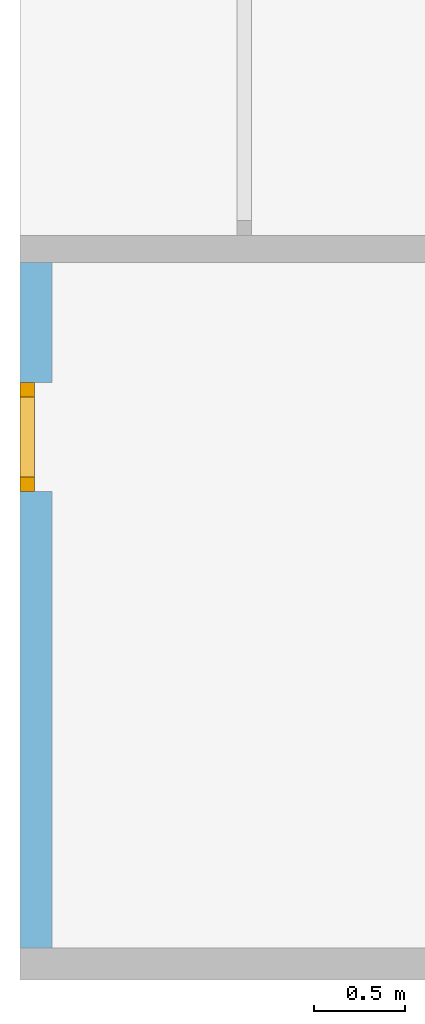
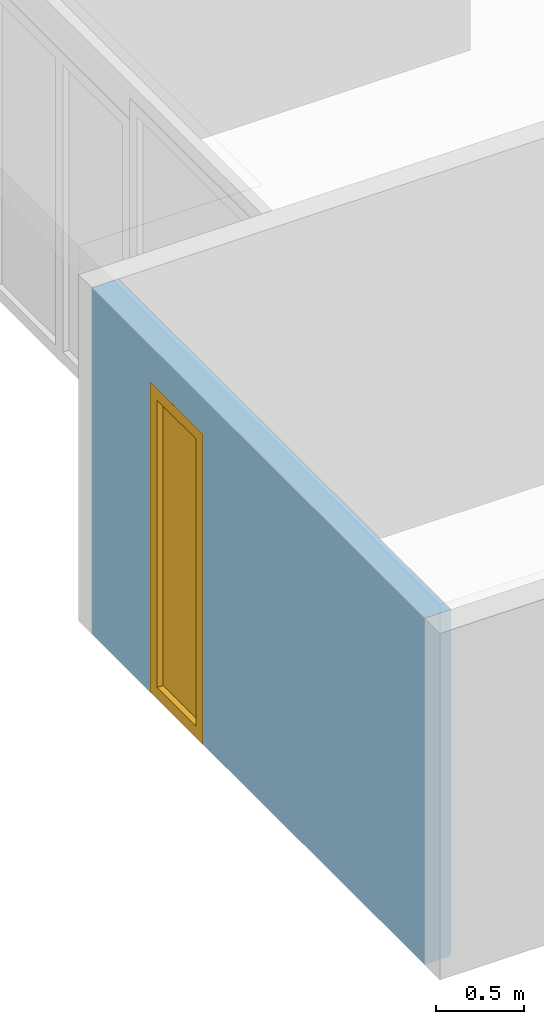
# One storey, part 2 of 8: 1 window, 1 opening, plus 1 element that does not belong to this part.
"""IFC2X3 building model written with IfcOpenShell, lengths in millimetres."""

from ifc_helpers import new_model, entity, si_unit, converted_unit, frame, frame_2d, origin, origin_with_axes, place, context, project, spatial, rectangle, extrude, faceted_brep, material, layer, layer_set, layer_usage, element, fill, save


model = new_model("IFC2X3")

# Units and contexts
model_context = context("Model", 3, precision=1e-05, world=origin())
plan_context = context("Plan", 3, precision=1e-05, world=origin())
ifc_project = project(units=[si_unit("LENGTHUNIT", "METRE", prefix="MILLI"), converted_unit("PLANEANGLEUNIT", "DEGREE", entity("IfcPlaneAngleMeasure", 0.0174532925199433), si_unit("PLANEANGLEUNIT", "RADIAN"), dimensions=[0, 0, 0, 0, 0, 0, 0]), si_unit("AREAUNIT", "SQUARE_METRE"), si_unit("VOLUMEUNIT", "CUBIC_METRE")], contexts=[model_context, plan_context])

# Building, storey
building_placement = place(None, origin())
building = spatial("IfcBuilding", under=ifc_project, at=building_placement, CompositionType="ELEMENT")
storey_placement = place(building_placement, frame((0.0, 0.0, 2900.0), z_axis=(0.0, 0.0, 1.0), x_axis=(1.0, 0.0, 0.0)))
storey = spatial("IfcBuildingStorey", under=building, at=storey_placement, Name="OG", CompositionType="ELEMENT", Elevation=2900.0)

# Wall, opening, window
ifc_material_1 = material(Name="B25")
ifc_layer = layer(ifc_material_1, 175.0)
ifc_layer_set = layer_set([ifc_layer])
ifc_layer_usage = layer_usage(ifc_layer_set, "AXIS2", "POSITIVE", 0.0)
wall_placement = place(storey_placement, frame((21188.3517822139, -4741.5625, 0.0), z_axis=(0.0, 0.0, 1.0), x_axis=(0.0, -1.0, 0.0)))
wall = element("IfcWallStandardCase", 1, at=wall_placement, inside=storey, material=ifc_layer_usage, context=model_context, shape_type="SweptSolid", body=[
    extrude(rectangle(XDim=3775.0, YDim=175.0, at=frame_2d((1887.5, 87.5), x_axis=(1.0, 0.0))), origin_with_axes(), (0.0, 0.0, 1.0), 2400.0),
])
opening_placement = place(wall_placement, frame((660.000000000001, 0.0, 0.0), z_axis=(0.0, 1.0, 0.0), x_axis=(0.0, 0.0, 1.0)))
opening = element("IfcOpeningElement", 2, at=opening_placement, cuts=wall, ObjectType="Opening", context=model_context, shape_type="SweptSolid", body=[
    extrude(rectangle(XDim=2150.0, YDim=600.0, at=frame_2d((1075.0, 300.0), x_axis=(1.0, 0.0))), origin_with_axes(), (0.0, 0.0, 1.0), 175.0),
])
ifc_material_2 = material()
window_placement = place(opening_placement, frame((0.0, 0.0, 0.0), z_axis=(1.0, 0.0, 0.0), x_axis=(0.0, 1.0, 0.0)))
window = element("IfcWindow", 3, at=window_placement, inside=storey, material=ifc_material_2, Name="m", OverallHeight=2150.0, OverallWidth=600.0, context=model_context, shape_type="Brep", body=[
    faceted_brep([(520.0, 4.36074509835294e-11, 0.0), (520.0, 4.36074509835294e-11, 2150.0), (600.0, 4.3602566002221e-11, 2150.0), (600.0, 4.3602566002221e-11, 0.0), (600.0, 80.0000000000436, 0.0), (600.0, 80.0000000000436, 2150.0), (520.0, 80.0000000000436, 2150.0), (520.0, 80.0000000000436, 0.0), (600.0, 4.3602566002221e-11, 0.0), (600.0, 80.0000000000436, 0.0), (520.0, 80.0000000000436, 0.0), (520.0, 4.36074509835294e-11, 0.0), (600.0, 4.3602566002221e-11, 2150.0), (600.0, 80.0000000000436, 2150.0), (600.0, 80.0000000000436, 0.0), (600.0, 4.3602566002221e-11, 0.0), (520.0, 4.36074509835294e-11, 2150.0), (520.0, 80.0000000000436, 2150.0), (600.0, 80.0000000000436, 2150.0), (600.0, 4.3602566002221e-11, 2150.0), (520.0, 4.36074509835294e-11, 0.0), (520.0, 80.0000000000436, 0.0), (520.0, 80.0000000000436, 2150.0), (520.0, 4.36074509835294e-11, 2150.0)], [[[0, 1, 2, 3]], [[4, 5, 6, 7]], [[8, 9, 10, 11]], [[12, 13, 14, 15]], [[16, 17, 18, 19]], [[20, 21, 22, 23]]], orient=[[False], [False], [False], [False], [False], [False]]),
    faceted_brep([(80.0, 4.3630876689349e-11, 2150.0), (80.0, 4.3630876689349e-11, 0.0), (-3.67381906139149e-17, 4.36357616706573e-11, 0.0), (-3.67381906139149e-17, 4.36357616706573e-11, 2150.0), (4.8616872246756e-15, 80.0000000000436, 2150.0), (4.8616872246756e-15, 80.0000000000436, 0.0), (80.0, 80.0000000000436, 0.0), (80.0, 80.0000000000436, 2150.0), (-3.67381906139149e-17, 4.36357616706573e-11, 2150.0), (4.8616872246756e-15, 80.0000000000436, 2150.0), (80.0, 80.0000000000436, 2150.0), (80.0, 4.3630876689349e-11, 2150.0), (-3.67381906139149e-17, 4.36357616706573e-11, 0.0), (4.8616872246756e-15, 80.0000000000436, 0.0), (4.8616872246756e-15, 80.0000000000436, 2150.0), (-3.67381906139149e-17, 4.36357616706573e-11, 2150.0), (80.0, 4.3630876689349e-11, 0.0), (80.0, 80.0000000000436, 0.0), (4.8616872246756e-15, 80.0000000000436, 0.0), (-3.67381906139149e-17, 4.36357616706573e-11, 0.0), (80.0, 4.3630876689349e-11, 2150.0), (80.0, 80.0000000000436, 2150.0), (80.0, 80.0000000000436, 0.0), (80.0, 4.3630876689349e-11, 0.0)], [[[0, 1, 2, 3]], [[4, 5, 6, 7]], [[8, 9, 10, 11]], [[12, 13, 14, 15]], [[16, 17, 18, 19]], [[20, 21, 22, 23]]], orient=[[False], [False], [False], [False], [False], [False]]),
    faceted_brep([(520.0, 4.36216618382446e-11, 2070.0), (80.0, 4.3648640257743e-11, 2070.0), (80.0, 4.3648640257743e-11, 2150.0), (520.0, 4.36216618382446e-11, 2150.0), (520.0, 80.0000000000436, 2150.0), (80.0, 80.0000000000436, 2150.0), (80.0, 80.0000000000436, 2070.0), (520.0, 80.0000000000436, 2070.0), (520.0, 4.36216618382446e-11, 2150.0), (520.0, 80.0000000000436, 2150.0), (520.0, 80.0000000000436, 2070.0), (520.0, 4.36216618382446e-11, 2070.0), (80.0, 4.3648640257743e-11, 2150.0), (80.0, 80.0000000000436, 2150.0), (520.0, 80.0000000000436, 2150.0), (520.0, 4.36216618382446e-11, 2150.0), (80.0, 4.3648640257743e-11, 2070.0), (80.0, 80.0000000000436, 2070.0), (80.0, 80.0000000000436, 2150.0), (80.0, 4.3648640257743e-11, 2150.0), (520.0, 4.36216618382446e-11, 2070.0), (520.0, 80.0000000000436, 2070.0), (80.0, 80.0000000000436, 2070.0), (80.0, 4.3648640257743e-11, 2070.0)], [[[0, 1, 2, 3]], [[4, 5, 6, 7]], [[8, 9, 10, 11]], [[12, 13, 14, 15]], [[16, 17, 18, 19]], [[20, 21, 22, 23]]], orient=[[False], [False], [False], [False], [False], [False]]),
    faceted_brep([(80.0, 4.3648640257743e-11, 80.0), (520.0, 4.36216618382446e-11, 80.0), (520.0, 4.36216618382446e-11, 0.0), (80.0, 4.3648640257743e-11, 0.0), (80.0, 80.0000000000436, 0.0), (520.0, 80.0000000000436, 0.0), (520.0, 80.0000000000436, 80.0), (80.0, 80.0000000000436, 80.0), (80.0, 4.3648640257743e-11, 0.0), (80.0, 80.0000000000436, 0.0), (80.0, 80.0000000000436, 80.0), (80.0, 4.3648640257743e-11, 80.0), (520.0, 4.36216618382446e-11, 0.0), (520.0, 80.0000000000436, 0.0), (80.0, 80.0000000000436, 0.0), (80.0, 4.3648640257743e-11, 0.0), (520.0, 4.36216618382446e-11, 80.0), (520.0, 80.0000000000436, 80.0), (520.0, 80.0000000000436, 0.0), (520.0, 4.36216618382446e-11, 0.0), (80.0, 4.3648640257743e-11, 80.0), (80.0, 80.0000000000436, 80.0), (520.0, 80.0000000000436, 80.0), (520.0, 4.36216618382446e-11, 80.0)], [[[0, 1, 2, 3]], [[4, 5, 6, 7]], [[8, 9, 10, 11]], [[12, 13, 14, 15]], [[16, 17, 18, 19]], [[20, 21, 22, 23]]], orient=[[False], [False], [False], [False], [False], [False]]),
    faceted_brep([(520.0, 40.0000000000436, 80.0), (80.0, 40.0000000000436, 80.0), (80.0, 40.0000000000436, 2070.0), (520.0, 40.0000000000436, 2070.0), (520.0, 41.0000000000436, 80.0), (520.0, 41.0000000000436, 2070.0), (80.0, 41.0000000000436, 2070.0), (80.0, 41.0000000000436, 80.0), (520.0, 40.0000000000436, 80.0), (520.0, 41.0000000000436, 80.0), (80.0, 41.0000000000436, 80.0), (80.0, 40.0000000000436, 80.0), (80.0, 40.0000000000436, 80.0), (80.0, 41.0000000000436, 80.0), (80.0, 41.0000000000436, 2070.0), (80.0, 40.0000000000436, 2070.0), (80.0, 40.0000000000436, 2070.0), (80.0, 41.0000000000436, 2070.0), (520.0, 41.0000000000436, 2070.0), (520.0, 40.0000000000436, 2070.0), (520.0, 40.0000000000436, 2070.0), (520.0, 41.0000000000436, 2070.0), (520.0, 41.0000000000436, 80.0), (520.0, 40.0000000000436, 80.0)], [[[0, 1, 2, 3]], [[4, 5, 6, 7]], [[8, 9, 10, 11]], [[12, 13, 14, 15]], [[16, 17, 18, 19]], [[20, 21, 22, 23]]], orient=[[False], [False], [False], [False], [False], [False]]),
])
fill(opening, window)

save(model, "model.ifc")
